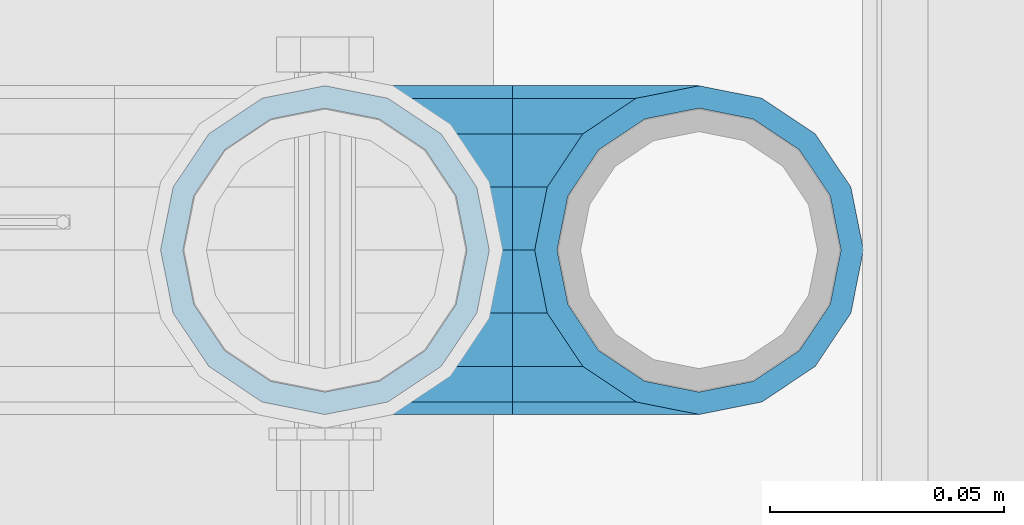
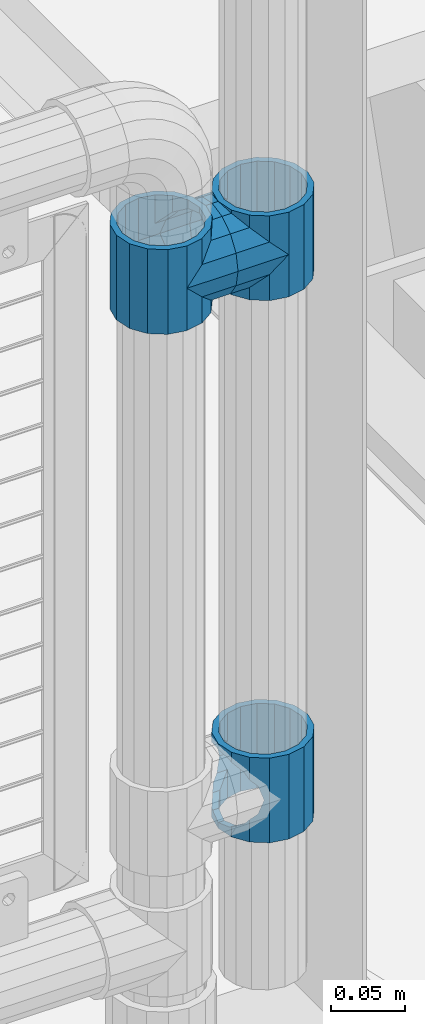
# One storey, part 140 of 208: 5 beams.
"""IFC2X3 building model written with IfcOpenShell, lengths in millimetres."""

from ifc_helpers import new_model, si_unit, frame, origin_with_axes, place, context, subcontext, project, spatial, faceted_brep, material, type_object, element, save


model = new_model("IFC2X3")

# Units and contexts
model_context = context("Model", 3, precision=1e-05, world=origin_with_axes())
body_context = subcontext(model_context, "Body", "Model", "MODEL_VIEW")
ifc_project = project(units=[si_unit("LENGTHUNIT", "METRE", prefix="MILLI"), si_unit("AREAUNIT", "SQUARE_METRE"), si_unit("VOLUMEUNIT", "CUBIC_METRE"), si_unit("MASSUNIT", "GRAM", prefix="KILO"), si_unit("TIMEUNIT", "SECOND"), si_unit("PLANEANGLEUNIT", "RADIAN"), si_unit("SOLIDANGLEUNIT", "STERADIAN"), si_unit("THERMODYNAMICTEMPERATUREUNIT", "DEGREE_CELSIUS"), si_unit("LUMINOUSINTENSITYUNIT", "LUMEN")], contexts=[model_context])

# Site, building, storey
site_placement = place(None, origin_with_axes())
site = spatial("IfcSite", under=ifc_project, at=site_placement, CompositionType="ELEMENT")
building_placement = place(site_placement, origin_with_axes())
building = spatial("IfcBuilding", under=site, at=building_placement, Name="Standard", CompositionType="ELEMENT")
storey_placement = place(building_placement, origin_with_axes())
storey = spatial("IfcBuildingStorey", under=building, at=storey_placement, Name="Undefined", CompositionType="ELEMENT", Elevation=0.0)

# Beams
ifc_material = material(Name="Misc_Undefined")
beam_type = type_object("IfcBeamType", PredefinedType="NOTDEFINED")
beam_1_placement = place(storey_placement, frame((-26149.0, 4664.5, 433.82), z_axis=(1.0, 0.0, 0.0), x_axis=(0.0, 0.0, -1.0)))
element("IfcBeam", 1, at=beam_1_placement, inside=storey, type_object=beam_type, material=ifc_material, context=body_context, shape_type="Brep", body=[
    faceted_brep([(56.6106908090114, 21.4606908090118, -27.1226768591077), (56.6106908090114, 21.4606908090118, -21.4606908090136), (46.7644421722801, 28.0397438117179, -11.6144421722784), (46.7644421722801, 28.0397438117179, -20.0882031229921), (51.531042408003, 24.8548033587067, -24.8548033587067), (63.1897438117172, 11.6144421722802, -32.8397438117245), (63.1897438117172, 11.6144421722802, -28.0397438117143), (61.962379517676, 13.4513226476329, -32.4743655677739), (65.4999999999997, 0.0, -35.1500000000015), (65.4999999999997, 0.0, -30.3499999999985), (63.1897438117172, -11.6144421722802, -32.8397438117245), (63.1897438117172, -11.6144421722802, -28.0397438117143), (61.962379517675, -13.4513226476329, -32.4743655677739), (56.6106908090114, -21.4606908090118, -27.1226768591005), (56.6106908090114, -21.4606908090118, -21.4606908090136), (51.531042408003, -24.8548033587067, -24.8548033587067), (46.7644421722801, -28.0397438117179, -20.0882031229921), (46.7644421722801, -28.0397438117179, -11.6144421722784), (35.1499999999996, -30.3500000000004, -16.6306603983685), (35.1500000000015, -30.35, 0.0), (23.5355578277191, -28.0397438117179, -20.0882031229921), (23.5355578277191, -28.0397438117179, -11.6144421722784), (13.6893091909879, -21.4606908090118, -27.1226768591005), (13.6893091909879, -21.4606908090118, -21.4606908090136), (18.7689575919962, -24.8548033587067, -24.8548033587067), (7.11025618828205, -11.6144421722802, -32.8397438117245), (7.11025618828205, -11.6144421722802, -28.0397438117143), (8.33762048232325, -13.4513226476329, -32.4743655677739), (4.79999999999961, 0.0, -35.1500000000015), (4.79999999999961, 0.0, -30.3499999999985), (7.11025618828211, 11.6144421722802, -32.8397438117245), (7.11025618828211, 11.6144421722802, -28.0397438117143), (8.33762048232325, 13.4513226476329, -32.4743655677739), (13.6893091909879, 21.4606908090118, -27.1226768591077), (13.6893091909879, 21.4606908090118, -21.4606908090136), (18.7689575919962, 24.8548033587067, -24.8548033587067), (23.5355578277192, 28.0397438117179, -20.0882031229921), (23.5355578277192, 28.0397438117179, -11.6144421722784), (35.1499999999996, 30.3500000000004, -16.6306603983685), (35.1500000000015, 30.35, 0.0), (0.0, 32.4743655677721, -13.4513226476338), (0.0, 35.1499999999996, 0.0), (70.2999999999993, 35.1499999999996, 0.0), (70.2999999999993, 32.4743655677721, -13.4513226476338), (0.0, 32.4743655677721, 13.4513226476338), (70.2999999999993, 32.4743655677721, 13.4513226476338), (0.0, 24.8548033587067, 24.8548033587067), (70.2999999999993, 24.8548033587067, 24.8548033587067), (0.0, 13.4513226476329, 32.4743655677739), (70.2999999999993, 13.4513226476329, 32.4743655677739), (0.0, 0.0, 35.1499999999996), (70.2999999999993, 0.0, 35.1500000000015), (0.0, -13.4513226476329, 32.4743655677739), (70.2999999999993, -13.4513226476329, 32.4743655677739), (0.0, -24.8548033587067, 24.8548033587067), (70.2999999999993, -24.8548033587067, 24.8548033587067), (0.0, -32.4743655677721, 13.4513226476338), (70.2999999999993, -32.4743655677721, 13.4513226476338), (0.0, -35.1499999999996, 0.0), (70.2999999999993, -35.1499999999996, 0.0), (70.2999999999993, -30.3500000000004, 0.0), (70.2999999999993, -28.0397438117179, -11.6144421722784), (70.2999999999993, -21.4606908090118, -21.4606908090136), (70.2999999999993, -11.6144421722802, -28.0397438117143), (70.2999999999993, 0.0, -30.3499999999985), (70.2999999999993, 11.6144421722802, -28.0397438117143), (70.2999999999993, 21.4606908090118, -21.4606908090136), (70.2999999999993, 28.0397438117179, -11.6144421722784), (0.0, -28.0397438117179, -11.6144421722784), (0.0, -30.3500000000004, 0.0), (0.0, -21.4606908090118, -21.4606908090136), (0.0, -11.6144421722802, -28.0397438117143), (0.0, 0.0, -30.3499999999985), (0.0, 11.6144421722802, -28.0397438117143), (0.0, 21.4606908090118, -21.4606908090136), (0.0, 28.0397438117179, -11.6144421722784), (0.0, 30.3500000000004, 0.0), (70.2999999999993, 30.3500000000004, 0.0), (0.0, 28.0397438117179, 11.6144421722784), (70.2999999999993, 28.0397438117179, 11.6144421722784), (0.0, 21.4606908090118, 21.4606908090136), (70.2999999999993, 21.4606908090118, 21.4606908090136), (0.0, 11.6144421722802, 28.0397438117143), (70.2999999999993, 11.6144421722802, 28.0397438117143), (0.0, 0.0, 30.3499999999985), (70.2999999999993, 0.0, 30.3499999999985), (0.0, -11.6144421722802, 28.0397438117143), (70.2999999999993, -11.6144421722802, 28.0397438117143), (0.0, -21.4606908090118, 21.4606908090136), (70.2999999999993, -21.4606908090118, 21.4606908090136), (0.0, -28.0397438117179, 11.6144421722784), (70.2999999999993, -28.0397438117179, 11.6144421722784), (70.2999999999993, -24.8548033587067, -24.8548033587067), (70.2999999999993, -13.4513226476329, -32.4743655677739), (70.2999999999993, 0.0, -35.1500000000015), (70.2999999999993, 13.4513226476329, -32.4743655677739), (70.2999999999993, 24.8548033587067, -24.8548033587067), (70.2999999999993, -32.4743655677721, -13.4513226476338), (0.0, -32.4743655677721, -13.4513226476338), (0.0, 24.8548033587067, -24.8548033587067), (0.0, 13.4513226476329, -32.4743655677739), (0.0, 0.0, -35.1499999999996), (0.0, -13.4513226476329, -32.4743655677739), (0.0, -24.8548033587067, -24.8548033587067)], [[[0, 1, 2, 3, 4]], [[5, 6, 1, 0, 7]], [[8, 9, 6, 5]], [[10, 11, 9, 8]], [[12, 13, 14, 11, 10]], [[15, 16, 17, 14, 13]], [[18, 19, 17, 16]], [[20, 21, 19, 18]], [[22, 23, 21, 20, 24]], [[25, 26, 23, 22, 27]], [[28, 29, 26, 25]], [[30, 31, 29, 28]], [[32, 33, 34, 31, 30]], [[35, 36, 37, 34, 33]], [[38, 39, 37, 36]], [[3, 2, 39, 38]], [[40, 41, 42, 43]], [[41, 44, 45, 42]], [[44, 46, 47, 45]], [[46, 48, 49, 47]], [[48, 50, 51, 49]], [[50, 52, 53, 51]], [[52, 54, 55, 53]], [[54, 56, 57, 55]], [[56, 58, 59, 57]], [[60, 61, 17, 19]], [[61, 62, 14, 17]], [[62, 63, 11, 14]], [[63, 64, 9, 11]], [[64, 65, 6, 9]], [[65, 66, 1, 6]], [[66, 67, 2, 1]], [[68, 69, 19, 21]], [[70, 68, 21, 23]], [[71, 70, 23, 26]], [[72, 71, 26, 29]], [[73, 72, 29, 31]], [[74, 73, 31, 34]], [[75, 74, 34, 37]], [[76, 75, 37, 39]], [[67, 77, 39, 2]], [[78, 76, 39, 77, 79]], [[80, 78, 79, 81]], [[82, 80, 81, 83]], [[84, 82, 83, 85]], [[86, 84, 85, 87]], [[88, 86, 87, 89]], [[90, 88, 89, 91]], [[19, 69, 90, 91, 60]], [[92, 93, 94, 95, 96, 43, 42, 45, 47, 49, 51, 53, 55, 57, 59, 97], [89, 87, 85, 83, 81, 79, 77, 67, 66, 65, 64, 63, 62, 61, 60, 91]], [[58, 98, 97, 59]], [[56, 54, 52, 50, 48, 46, 44, 41, 40, 99, 100, 101, 102, 103, 98, 58], [68, 70, 71, 72, 73, 74, 75, 76, 78, 80, 82, 84, 86, 88, 90, 69]], [[100, 99, 35, 33, 32]], [[101, 100, 32, 30, 28]], [[27, 102, 101, 28, 25]], [[24, 103, 102, 27, 22]], [[92, 97, 98, 103, 24, 20, 18, 16, 15]], [[93, 92, 15, 13, 12]], [[94, 93, 12, 10, 8]], [[7, 95, 94, 8, 5]], [[4, 96, 95, 7, 0]], [[38, 36, 35, 99, 40, 43, 96, 4, 3]]]),
])
beam_2_placement = place(storey_placement, frame((-26229.0, 4664.5, 848.670000000001), z_axis=(0.0, -1.0, 0.0), x_axis=(1.0, 0.0, 0.0)))
element("IfcBeam", 2, at=beam_2_placement, inside=storey, type_object=beam_type, material=ifc_material, context=body_context, shape_type="Brep", body=[
    faceted_brep([(13.4513226476338, -13.4513226476329, -32.4743655677721), (13.4513226476338, 13.4513226476329, -32.4743655677721), (0.0, 0.0, -35.1499999999996), (27.1226768591005, 21.4606908090117, 21.4606908090118), (24.8548033587067, 16.3810424080032, 24.8548033587067), (24.8548033587067, 24.8548033587072, 24.8548033587067), (32.4743655677739, 32.4743655677717, 13.4513226476329), (32.4743655677739, 26.812379517676, 13.4513226476329), (0.0, 0.0, 35.1499999999996), (13.4513226476338, 13.4513226476329, 32.4743655677721), (13.4513226476338, -13.4513226476329, 32.4743655677721), (20.0882031229921, 11.6144421722805, 28.0397438117179), (16.6306603983685, 0.0, 30.3500000000004), (20.0882031229921, -11.6144421722805, 28.0397438117179), (24.8548033587067, -16.3810424080039, 24.8548033587067), (24.8548033587067, -24.8548033587072, 24.8548033587067), (27.1226768591005, -21.4606908090117, 21.4606908090118), (32.4743655677739, -26.8123795176755, 13.4513226476329), (32.4743655677739, -32.4743655677717, 13.4513226476329), (32.8397438117172, -28.0397438117175, 11.6144421722802), (35.1500000000015, -30.35, 0.0), (35.1500000000015, -35.1499999999996, 0.0), (32.8397438117172, -28.0397438117175, -11.6144421722802), (32.4743655677739, -26.8123795176766, -13.4513226476329), (32.4743655677739, -32.4743655677717, -13.4513226476329), (27.1226768591077, -21.4606908090117, -21.4606908090118), (24.8548033587067, -16.3810424080039, -24.8548033587067), (24.8548033587067, -24.8548033587072, -24.8548033587067), (20.0882031229849, -11.6144421722805, -28.0397438117179), (16.6306603983685, 0.0, -30.3500000000004), (20.0882031229849, 11.6144421722805, -28.0397438117179), (24.8548033587067, 16.3810424080023, -24.8548033587067), (24.8548033587067, 24.8548033587072, -24.8548033587067), (32.4743655677739, 26.8123795176755, -13.4513226476329), (32.4743655677739, 32.4743655677717, -13.4513226476329), (27.1226768591077, 21.4606908090117, -21.4606908090118), (35.1500000000015, 30.35, 0.0), (35.1500000000015, 35.15, 0.0), (32.8397438117172, 28.0397438117175, -11.6144421722802), (32.8397438117172, 28.0397438117175, 11.6144421722802), (40.1500000000015, -35.15, 0.0), (40.1500000000015, -32.4743655677717, 13.4513226476329), (40.1500000000015, -24.8548033587072, 24.8548033587067), (40.1500000000015, -13.4513226476329, 32.4743655677721), (40.1500000000015, 0.0, 35.1499999999996), (40.1500000000015, 13.4513226476329, 32.4743655677721), (40.1500000000015, 24.8548033587072, 24.8548033587067), (40.1500000000015, 32.4743655677717, 13.4513226476329), (40.1500000000015, 35.15, 0.0), (40.1500000000015, -24.8548033587072, -24.8548033587067), (40.1500000000015, -32.4743655677717, -13.4513226476329), (40.1500000000015, -13.4513226476329, -32.4743655677721), (40.1500000000015, 0.0, -35.1499999999996), (40.1500000000015, 13.4513226476329, -32.4743655677721), (40.1500000000015, 24.8548033587072, -24.8548033587067), (40.1500000000015, 32.4743655677717, -13.4513226476329), (40.1500000000015, -21.4606908090117, 21.4606908090118), (40.1500000000015, -11.6144421722805, 28.0397438117179), (40.1500000000015, 0.0, 30.3500000000004), (40.1500000000015, 11.6144421722805, 28.0397438117179), (40.1500000000015, 21.4606908090117, 21.4606908090118), (40.1500000000015, 28.0397438117175, 11.6144421722802), (40.1500000000015, 30.35, 0.0), (40.1500000000015, 28.0397438117175, -11.6144421722802), (40.1500000000015, 21.4606908090117, -21.4606908090118), (40.1500000000015, 11.6144421722805, -28.0397438117179), (40.1500000000015, 0.0, -30.3500000000004), (40.1500000000015, -11.6144421722805, -28.0397438117179), (40.1500000000015, -21.4606908090117, -21.4606908090118), (40.1500000000015, -28.0397438117175, -11.6144421722802), (40.1500000000015, -30.35, 0.0), (40.1500000000015, -28.0397438117175, 11.6144421722802)], [[[0, 1, 2]], [[3, 4, 5, 6, 7]], [[8, 9, 10]], [[10, 9, 5, 4, 11, 12, 13, 14, 15]], [[15, 14, 16, 17, 18]], [[18, 17, 19, 20, 21]], [[21, 20, 22, 23, 24]], [[24, 23, 25, 26, 27]], [[27, 26, 28, 29, 30, 31, 32, 1, 0]], [[33, 34, 32, 31, 35]], [[36, 37, 34, 33, 38]], [[39, 7, 6, 37, 36]], [[40, 41, 18, 21]], [[41, 42, 15, 18]], [[42, 43, 10, 15]], [[43, 44, 8, 10]], [[44, 45, 9, 8]], [[45, 46, 5, 9]], [[46, 47, 6, 5]], [[47, 48, 37, 6]], [[49, 50, 24, 27]], [[51, 49, 27, 0]], [[52, 51, 0, 2]], [[53, 52, 2, 1]], [[54, 53, 1, 32]], [[55, 54, 32, 34]], [[48, 55, 34, 37]], [[50, 40, 21, 24]], [[49, 51, 52, 53, 54, 55, 48, 47, 46, 45, 44, 43, 42, 41, 40, 50], [56, 57, 58, 59, 60, 61, 62, 63, 64, 65, 66, 67, 68, 69, 70, 71]], [[63, 62, 36, 38]], [[35, 64, 63, 38, 33]], [[30, 65, 64, 35, 31]], [[66, 65, 30, 29]], [[67, 66, 29, 28]], [[68, 67, 28, 26, 25]], [[69, 68, 25, 23, 22]], [[70, 69, 22, 20]], [[71, 70, 20, 19]], [[16, 56, 71, 19, 17]], [[13, 57, 56, 16, 14]], [[58, 57, 13, 12]], [[59, 58, 12, 11]], [[60, 59, 11, 4, 3]], [[61, 60, 3, 7, 39]], [[62, 61, 39, 36]]]),
])
beam_3_placement = place(storey_placement, frame((-26149.0, 4664.5, 848.670000000001), z_axis=(0.0, 1.0, 0.0), x_axis=(-1.0, 0.0, 0.0)))
element("IfcBeam", 3, at=beam_3_placement, inside=storey, type_object=beam_type, material=ifc_material, context=body_context, shape_type="Brep", body=[
    faceted_brep([(13.4513226476338, -13.4513226476329, -32.4743655677721), (13.4513226476338, 13.4513226476329, -32.4743655677721), (0.0, 0.0, -35.1499999999996), (24.8548033587067, -24.8548033587072, 24.8548033587067), (24.8548033587067, -16.3810424080039, 24.8548033587067), (27.1226768591005, -21.4606908090117, 21.4606908090118), (32.4743655677739, -26.8123795176755, 13.4513226476329), (32.4743655677739, -32.4743655677717, 13.4513226476329), (32.8397438117172, -28.0397438117175, 11.6144421722802), (35.1500000000015, -30.35, 0.0), (35.1500000000015, -35.1499999999996, 0.0), (32.8397438117172, -28.0397438117175, -11.6144421722802), (32.4743655677739, -26.8123795176766, -13.4513226476329), (32.4743655677739, -32.4743655677717, -13.4513226476329), (27.1226768591077, -21.4606908090117, -21.4606908090118), (24.8548033587067, -16.3810424080039, -24.8548033587067), (24.8548033587067, -24.8548033587072, -24.8548033587067), (20.0882031229849, -11.6144421722805, -28.0397438117179), (16.6306603983685, 0.0, -30.3500000000004), (20.0882031229849, 11.6144421722805, -28.0397438117179), (24.8548033587067, 16.3810424080023, -24.8548033587067), (24.8548033587067, 24.8548033587072, -24.8548033587067), (32.4743655677739, 26.8123795176755, -13.4513226476329), (32.4743655677739, 32.4743655677717, -13.4513226476329), (27.1226768591077, 21.4606908090117, -21.4606908090118), (35.1500000000015, 30.35, 0.0), (35.1500000000015, 35.15, 0.0), (32.8397438117172, 28.0397438117175, -11.6144421722802), (32.8397438117172, 28.0397438117175, 11.6144421722802), (32.4743655677739, 26.812379517676, 13.4513226476329), (32.4743655677739, 32.4743655677717, 13.4513226476329), (27.1226768591005, 21.4606908090117, 21.4606908090118), (24.8548033587067, 16.3810424080032, 24.8548033587067), (24.8548033587067, 24.8548033587072, 24.8548033587067), (0.0, 0.0, 35.1499999999996), (13.4513226476338, 13.4513226476329, 32.4743655677721), (13.4513226476338, -13.4513226476329, 32.4743655677721), (20.0882031229921, 11.6144421722805, 28.0397438117179), (16.6306603983685, 0.0, 30.3500000000004), (20.0882031229921, -11.6144421722805, 28.0397438117179), (40.1500000000015, -35.15, 0.0), (40.1500000000015, -32.4743655677717, 13.4513226476329), (40.1500000000015, -24.8548033587072, 24.8548033587067), (40.1500000000015, -13.4513226476329, 32.4743655677721), (40.1500000000015, 0.0, 35.1499999999996), (40.1500000000015, -24.8548033587072, -24.8548033587067), (40.1500000000015, -32.4743655677717, -13.4513226476329), (40.1500000000015, -13.4513226476329, -32.4743655677721), (40.1500000000015, 0.0, -35.1499999999996), (40.1500000000015, 13.4513226476329, -32.4743655677721), (40.1500000000015, 24.8548033587072, -24.8548033587067), (40.1500000000015, 32.4743655677717, -13.4513226476329), (40.1500000000015, 35.15, 0.0), (40.1500000000015, 32.4743655677717, 13.4513226476329), (40.1500000000015, 24.8548033587072, 24.8548033587067), (40.1500000000015, 13.4513226476329, 32.4743655677721), (40.1500000000015, -21.4606908090117, 21.4606908090118), (40.1500000000015, -11.6144421722805, 28.0397438117179), (40.1500000000015, 0.0, 30.3500000000004), (40.1500000000015, 11.6144421722805, 28.0397438117179), (40.1500000000015, 21.4606908090117, 21.4606908090118), (40.1500000000015, 28.0397438117175, 11.6144421722802), (40.1500000000015, 30.35, 0.0), (40.1500000000015, 28.0397438117175, -11.6144421722802), (40.1500000000015, 21.4606908090117, -21.4606908090118), (40.1500000000015, 11.6144421722805, -28.0397438117179), (40.1500000000015, 0.0, -30.3500000000004), (40.1500000000015, -11.6144421722805, -28.0397438117179), (40.1500000000015, -21.4606908090117, -21.4606908090118), (40.1500000000015, -28.0397438117175, -11.6144421722802), (40.1500000000015, -30.35, 0.0), (40.1500000000015, -28.0397438117175, 11.6144421722802)], [[[0, 1, 2]], [[3, 4, 5, 6, 7]], [[7, 6, 8, 9, 10]], [[10, 9, 11, 12, 13]], [[13, 12, 14, 15, 16]], [[16, 15, 17, 18, 19, 20, 21, 1, 0]], [[22, 23, 21, 20, 24]], [[25, 26, 23, 22, 27]], [[28, 29, 30, 26, 25]], [[31, 32, 33, 30, 29]], [[34, 35, 36]], [[36, 35, 33, 32, 37, 38, 39, 4, 3]], [[40, 41, 7, 10]], [[41, 42, 3, 7]], [[42, 43, 36, 3]], [[43, 44, 34, 36]], [[45, 46, 13, 16]], [[47, 45, 16, 0]], [[48, 47, 0, 2]], [[49, 48, 2, 1]], [[50, 49, 1, 21]], [[51, 50, 21, 23]], [[52, 51, 23, 26]], [[53, 52, 26, 30]], [[54, 53, 30, 33]], [[55, 54, 33, 35]], [[44, 55, 35, 34]], [[46, 40, 10, 13]], [[45, 47, 48, 49, 50, 51, 52, 53, 54, 55, 44, 43, 42, 41, 40, 46], [56, 57, 58, 59, 60, 61, 62, 63, 64, 65, 66, 67, 68, 69, 70, 71]], [[59, 58, 38, 37]], [[60, 59, 37, 32, 31]], [[61, 60, 31, 29, 28]], [[62, 61, 28, 25]], [[63, 62, 25, 27]], [[24, 64, 63, 27, 22]], [[19, 65, 64, 24, 20]], [[66, 65, 19, 18]], [[67, 66, 18, 17]], [[68, 67, 17, 15, 14]], [[69, 68, 14, 12, 11]], [[70, 69, 11, 9]], [[71, 70, 9, 8]], [[5, 56, 71, 8, 6]], [[39, 57, 56, 5, 4]], [[58, 57, 39, 38]]]),
])
beam_4_placement = place(storey_placement, frame((-26229.0, 4664.5, 883.82), z_axis=(-1.0, 0.0, 0.0), x_axis=(0.0, 0.0, -1.0)))
element("IfcBeam", 4, at=beam_4_placement, inside=storey, type_object=beam_type, material=ifc_material, context=body_context, shape_type="Brep", body=[
    faceted_brep([(7.11025618828205, -11.6144421722802, -32.8397438117245), (7.11025618828205, -11.6144421722802, -28.0397438117143), (13.6893091909879, -21.4606908090118, -21.4606908090136), (13.6893091909879, -21.4606908090118, -27.1226768591005), (8.33762048232325, -13.4513226476329, -32.4743655677739), (23.5355578277191, -28.0397438117179, -11.6144421722784), (23.5355578277191, -28.0397438117179, -20.0882031229921), (18.7689575919962, -24.8548033587067, -24.8548033587067), (35.1500000000015, -30.35, 0.0), (35.1499999999996, -30.3500000000004, -16.6306603983685), (46.7644421722801, -28.0397438117179, -11.6144421722784), (46.7644421722801, -28.0397438117179, -20.0882031229921), (51.531042408003, -24.8548033587067, -24.8548033587067), (56.6106908090114, -21.4606908090118, -21.4606908090136), (56.6106908090114, -21.4606908090118, -27.1226768591005), (61.962379517675, -13.4513226476329, -32.4743655677739), (63.1897438117172, -11.6144421722802, -28.0397438117143), (63.1897438117172, -11.6144421722802, -32.8397438117245), (65.4999999999997, 0.0, -30.3499999999985), (65.4999999999997, 0.0, -35.1500000000015), (63.1897438117172, 11.6144421722802, -28.0397438117143), (63.1897438117172, 11.6144421722802, -32.8397438117245), (56.6106908090114, 21.4606908090118, -21.4606908090136), (56.6106908090114, 21.4606908090118, -27.1226768591077), (61.962379517676, 13.4513226476329, -32.4743655677739), (46.7644421722801, 28.0397438117179, -11.6144421722784), (46.7644421722801, 28.0397438117179, -20.0882031229921), (51.531042408003, 24.8548033587067, -24.8548033587067), (35.1500000000015, 30.35, 0.0), (35.1499999999996, 30.3500000000004, -16.6306603983685), (23.5355578277192, 28.0397438117179, -11.6144421722784), (23.5355578277192, 28.0397438117179, -20.0882031229921), (18.7689575919962, 24.8548033587067, -24.8548033587067), (13.6893091909879, 21.4606908090118, -21.4606908090136), (13.6893091909879, 21.4606908090118, -27.1226768591077), (8.33762048232325, 13.4513226476329, -32.4743655677739), (7.11025618828211, 11.6144421722802, -28.0397438117143), (7.11025618828211, 11.6144421722802, -32.8397438117245), (4.79999999999961, 0.0, -30.3499999999985), (4.79999999999961, 0.0, -35.1500000000015), (0.0, 21.4606908090118, 21.4606908090136), (0.0, 28.0397438117179, 11.6144421722784), (70.2999999999993, 28.0397438117179, 11.6144421722784), (70.2999999999993, 21.4606908090118, 21.4606908090136), (0.0, 11.6144421722802, 28.0397438117143), (70.2999999999993, 11.6144421722802, 28.0397438117143), (0.0, 0.0, 30.3499999999985), (70.2999999999993, 0.0, 30.3499999999985), (0.0, -11.6144421722802, 28.0397438117143), (70.2999999999993, -11.6144421722802, 28.0397438117143), (0.0, -21.4606908090118, 21.4606908090136), (70.2999999999993, -21.4606908090118, 21.4606908090136), (0.0, -28.0397438117179, 11.6144421722784), (70.2999999999993, -28.0397438117179, 11.6144421722784), (0.0, -24.8548033587067, -24.8548033587067), (0.0, -13.4513226476329, -32.4743655677739), (0.0, 0.0, -35.1499999999996), (0.0, -32.4743655677721, 13.4513226476338), (0.0, -35.1499999999996, 0.0), (70.2999999999993, -35.1499999999996, 0.0), (70.2999999999993, -32.4743655677721, 13.4513226476338), (0.0, -24.8548033587067, 24.8548033587067), (70.2999999999993, -24.8548033587067, 24.8548033587067), (0.0, -13.4513226476329, 32.4743655677739), (70.2999999999993, -13.4513226476329, 32.4743655677739), (0.0, 0.0, 35.1499999999996), (70.2999999999993, 0.0, 35.1500000000015), (0.0, 13.4513226476329, 32.4743655677739), (70.2999999999993, 13.4513226476329, 32.4743655677739), (0.0, 24.8548033587067, 24.8548033587067), (70.2999999999993, 24.8548033587067, 24.8548033587067), (0.0, 32.4743655677721, 13.4513226476338), (70.2999999999993, 32.4743655677721, 13.4513226476338), (0.0, 35.1499999999996, 0.0), (70.2999999999993, 35.1499999999996, 0.0), (0.0, 32.4743655677721, -13.4513226476338), (70.2999999999993, 32.4743655677721, -13.4513226476338), (70.2999999999993, -13.4513226476329, -32.4743655677739), (70.2999999999993, -24.8548033587067, -24.8548033587067), (70.2999999999993, 0.0, -35.1500000000015), (70.2999999999993, 13.4513226476329, -32.4743655677739), (70.2999999999993, 24.8548033587067, -24.8548033587067), (0.0, 24.8548033587067, -24.8548033587067), (0.0, 13.4513226476329, -32.4743655677739), (70.2999999999993, -32.4743655677721, -13.4513226476338), (0.0, -32.4743655677721, -13.4513226476338), (0.0, -28.0397438117179, -11.6144421722784), (0.0, -21.4606908090118, -21.4606908090136), (0.0, -11.6144421722802, -28.0397438117143), (0.0, 0.0, -30.3499999999985), (0.0, 11.6144421722802, -28.0397438117143), (0.0, 21.4606908090118, -21.4606908090136), (0.0, 28.0397438117179, -11.6144421722784), (0.0, 30.3500000000004, 0.0), (0.0, -30.3500000000004, 0.0), (70.2999999999993, 30.3500000000004, 0.0), (70.2999999999993, 28.0397438117179, -11.6144421722784), (70.2999999999993, 21.4606908090118, -21.4606908090136), (70.2999999999993, 11.6144421722802, -28.0397438117143), (70.2999999999993, 0.0, -30.3499999999985), (70.2999999999993, -11.6144421722802, -28.0397438117143), (70.2999999999993, -21.4606908090118, -21.4606908090136), (70.2999999999993, -28.0397438117179, -11.6144421722784), (70.2999999999993, -30.3500000000004, 0.0)], [[[0, 1, 2, 3, 4]], [[3, 2, 5, 6, 7]], [[6, 5, 8, 9]], [[9, 8, 10, 11]], [[12, 11, 10, 13, 14]], [[15, 14, 13, 16, 17]], [[17, 16, 18, 19]], [[19, 18, 20, 21]], [[21, 20, 22, 23, 24]], [[23, 22, 25, 26, 27]], [[26, 25, 28, 29]], [[29, 28, 30, 31]], [[32, 31, 30, 33, 34]], [[35, 34, 33, 36, 37]], [[37, 36, 38, 39]], [[39, 38, 1, 0]], [[40, 41, 42, 43]], [[44, 40, 43, 45]], [[46, 44, 45, 47]], [[48, 46, 47, 49]], [[50, 48, 49, 51]], [[52, 50, 51, 53]], [[7, 54, 55, 4, 3]], [[4, 55, 56, 39, 0]], [[57, 58, 59, 60]], [[61, 57, 60, 62]], [[63, 61, 62, 64]], [[65, 63, 64, 66]], [[67, 65, 66, 68]], [[69, 67, 68, 70]], [[71, 69, 70, 72]], [[73, 71, 72, 74]], [[75, 73, 74, 76]], [[77, 78, 12, 14, 15]], [[79, 77, 15, 17, 19]], [[24, 80, 79, 19, 21]], [[27, 81, 80, 24, 23]], [[29, 31, 32, 82, 75, 76, 81, 27, 26]], [[83, 82, 32, 34, 35]], [[56, 83, 35, 37, 39]], [[78, 84, 85, 54, 7, 6, 9, 11, 12]], [[58, 85, 84, 59]], [[57, 61, 63, 65, 67, 69, 71, 73, 75, 82, 83, 56, 55, 54, 85, 58], [86, 87, 88, 89, 90, 91, 92, 93, 41, 40, 44, 46, 48, 50, 52, 94]], [[90, 89, 38, 36]], [[91, 90, 36, 33]], [[92, 91, 33, 30]], [[93, 92, 30, 28]], [[41, 93, 28, 95, 42]], [[96, 95, 28, 25]], [[97, 96, 25, 22]], [[98, 97, 22, 20]], [[99, 98, 20, 18]], [[100, 99, 18, 16]], [[101, 100, 16, 13]], [[102, 101, 13, 10]], [[103, 102, 10, 8]], [[78, 77, 79, 80, 81, 76, 74, 72, 70, 68, 66, 64, 62, 60, 59, 84], [51, 49, 47, 45, 43, 42, 95, 96, 97, 98, 99, 100, 101, 102, 103, 53]], [[8, 94, 52, 53, 103]], [[86, 94, 8, 5]], [[87, 86, 5, 2]], [[88, 87, 2, 1]], [[89, 88, 1, 38]]]),
])
beam_5_placement = place(storey_placement, frame((-26149.0, 4664.5, 883.82), z_axis=(1.0, 0.0, 0.0), x_axis=(0.0, 0.0, -1.0)))
element("IfcBeam", 5, at=beam_5_placement, inside=storey, type_object=beam_type, material=ifc_material, context=body_context, shape_type="Brep", body=[
    faceted_brep([(56.6106908090114, 21.4606908090118, -27.1226768591077), (56.6106908090114, 21.4606908090118, -21.4606908090136), (46.7644421722801, 28.0397438117179, -11.6144421722784), (46.7644421722801, 28.0397438117179, -20.0882031229921), (51.531042408003, 24.8548033587067, -24.8548033587067), (63.1897438117172, 11.6144421722802, -32.8397438117245), (63.1897438117172, 11.6144421722802, -28.0397438117143), (61.962379517676, 13.4513226476329, -32.4743655677739), (65.4999999999997, 0.0, -35.1500000000015), (65.4999999999997, 0.0, -30.3499999999985), (63.1897438117172, -11.6144421722802, -32.8397438117245), (63.1897438117172, -11.6144421722802, -28.0397438117143), (61.962379517675, -13.4513226476329, -32.4743655677739), (56.6106908090114, -21.4606908090118, -27.1226768591005), (56.6106908090114, -21.4606908090118, -21.4606908090136), (51.531042408003, -24.8548033587067, -24.8548033587067), (46.7644421722801, -28.0397438117179, -20.0882031229921), (46.7644421722801, -28.0397438117179, -11.6144421722784), (35.1499999999996, -30.3500000000004, -16.6306603983685), (35.1500000000015, -30.35, 0.0), (23.5355578277191, -28.0397438117179, -20.0882031229921), (23.5355578277191, -28.0397438117179, -11.6144421722784), (13.6893091909879, -21.4606908090118, -27.1226768591005), (13.6893091909879, -21.4606908090118, -21.4606908090136), (18.7689575919962, -24.8548033587067, -24.8548033587067), (7.11025618828205, -11.6144421722802, -32.8397438117245), (7.11025618828205, -11.6144421722802, -28.0397438117143), (8.33762048232325, -13.4513226476329, -32.4743655677739), (4.79999999999961, 0.0, -35.1500000000015), (4.79999999999961, 0.0, -30.3499999999985), (7.11025618828211, 11.6144421722802, -32.8397438117245), (7.11025618828211, 11.6144421722802, -28.0397438117143), (8.33762048232325, 13.4513226476329, -32.4743655677739), (13.6893091909879, 21.4606908090118, -27.1226768591077), (13.6893091909879, 21.4606908090118, -21.4606908090136), (18.7689575919962, 24.8548033587067, -24.8548033587067), (23.5355578277192, 28.0397438117179, -20.0882031229921), (23.5355578277192, 28.0397438117179, -11.6144421722784), (35.1499999999996, 30.3500000000004, -16.6306603983685), (35.1500000000015, 30.35, 0.0), (0.0, 32.4743655677721, -13.4513226476338), (0.0, 35.1499999999996, 0.0), (70.2999999999993, 35.1499999999996, 0.0), (70.2999999999993, 32.4743655677721, -13.4513226476338), (0.0, 32.4743655677721, 13.4513226476338), (70.2999999999993, 32.4743655677721, 13.4513226476338), (0.0, 24.8548033587067, 24.8548033587067), (70.2999999999993, 24.8548033587067, 24.8548033587067), (0.0, 13.4513226476329, 32.4743655677739), (70.2999999999993, 13.4513226476329, 32.4743655677739), (0.0, 0.0, 35.1499999999996), (70.2999999999993, 0.0, 35.1500000000015), (0.0, -13.4513226476329, 32.4743655677739), (70.2999999999993, -13.4513226476329, 32.4743655677739), (0.0, -24.8548033587067, 24.8548033587067), (70.2999999999993, -24.8548033587067, 24.8548033587067), (0.0, -32.4743655677721, 13.4513226476338), (70.2999999999993, -32.4743655677721, 13.4513226476338), (0.0, -35.1499999999996, 0.0), (70.2999999999993, -35.1499999999996, 0.0), (70.2999999999993, -30.3500000000004, 0.0), (70.2999999999993, -28.0397438117179, -11.6144421722784), (70.2999999999993, -21.4606908090118, -21.4606908090136), (70.2999999999993, -11.6144421722802, -28.0397438117143), (70.2999999999993, 0.0, -30.3499999999985), (70.2999999999993, 11.6144421722802, -28.0397438117143), (70.2999999999993, 21.4606908090118, -21.4606908090136), (70.2999999999993, 28.0397438117179, -11.6144421722784), (0.0, -28.0397438117179, -11.6144421722784), (0.0, -30.3500000000004, 0.0), (0.0, -21.4606908090118, -21.4606908090136), (0.0, -11.6144421722802, -28.0397438117143), (0.0, 0.0, -30.3499999999985), (0.0, 11.6144421722802, -28.0397438117143), (0.0, 21.4606908090118, -21.4606908090136), (0.0, 28.0397438117179, -11.6144421722784), (0.0, 30.3500000000004, 0.0), (70.2999999999993, 30.3500000000004, 0.0), (0.0, 28.0397438117179, 11.6144421722784), (70.2999999999993, 28.0397438117179, 11.6144421722784), (0.0, 21.4606908090118, 21.4606908090136), (70.2999999999993, 21.4606908090118, 21.4606908090136), (0.0, 11.6144421722802, 28.0397438117143), (70.2999999999993, 11.6144421722802, 28.0397438117143), (0.0, 0.0, 30.3499999999985), (70.2999999999993, 0.0, 30.3499999999985), (0.0, -11.6144421722802, 28.0397438117143), (70.2999999999993, -11.6144421722802, 28.0397438117143), (0.0, -21.4606908090118, 21.4606908090136), (70.2999999999993, -21.4606908090118, 21.4606908090136), (0.0, -28.0397438117179, 11.6144421722784), (70.2999999999993, -28.0397438117179, 11.6144421722784), (70.2999999999993, -24.8548033587067, -24.8548033587067), (70.2999999999993, -13.4513226476329, -32.4743655677739), (70.2999999999993, 0.0, -35.1500000000015), (70.2999999999993, 13.4513226476329, -32.4743655677739), (70.2999999999993, 24.8548033587067, -24.8548033587067), (70.2999999999993, -32.4743655677721, -13.4513226476338), (0.0, -32.4743655677721, -13.4513226476338), (0.0, 24.8548033587067, -24.8548033587067), (0.0, 13.4513226476329, -32.4743655677739), (0.0, 0.0, -35.1499999999996), (0.0, -13.4513226476329, -32.4743655677739), (0.0, -24.8548033587067, -24.8548033587067)], [[[0, 1, 2, 3, 4]], [[5, 6, 1, 0, 7]], [[8, 9, 6, 5]], [[10, 11, 9, 8]], [[12, 13, 14, 11, 10]], [[15, 16, 17, 14, 13]], [[18, 19, 17, 16]], [[20, 21, 19, 18]], [[22, 23, 21, 20, 24]], [[25, 26, 23, 22, 27]], [[28, 29, 26, 25]], [[30, 31, 29, 28]], [[32, 33, 34, 31, 30]], [[35, 36, 37, 34, 33]], [[38, 39, 37, 36]], [[3, 2, 39, 38]], [[40, 41, 42, 43]], [[41, 44, 45, 42]], [[44, 46, 47, 45]], [[46, 48, 49, 47]], [[48, 50, 51, 49]], [[50, 52, 53, 51]], [[52, 54, 55, 53]], [[54, 56, 57, 55]], [[56, 58, 59, 57]], [[60, 61, 17, 19]], [[61, 62, 14, 17]], [[62, 63, 11, 14]], [[63, 64, 9, 11]], [[64, 65, 6, 9]], [[65, 66, 1, 6]], [[66, 67, 2, 1]], [[68, 69, 19, 21]], [[70, 68, 21, 23]], [[71, 70, 23, 26]], [[72, 71, 26, 29]], [[73, 72, 29, 31]], [[74, 73, 31, 34]], [[75, 74, 34, 37]], [[76, 75, 37, 39]], [[67, 77, 39, 2]], [[78, 76, 39, 77, 79]], [[80, 78, 79, 81]], [[82, 80, 81, 83]], [[84, 82, 83, 85]], [[86, 84, 85, 87]], [[88, 86, 87, 89]], [[90, 88, 89, 91]], [[19, 69, 90, 91, 60]], [[92, 93, 94, 95, 96, 43, 42, 45, 47, 49, 51, 53, 55, 57, 59, 97], [89, 87, 85, 83, 81, 79, 77, 67, 66, 65, 64, 63, 62, 61, 60, 91]], [[58, 98, 97, 59]], [[56, 54, 52, 50, 48, 46, 44, 41, 40, 99, 100, 101, 102, 103, 98, 58], [68, 70, 71, 72, 73, 74, 75, 76, 78, 80, 82, 84, 86, 88, 90, 69]], [[100, 99, 35, 33, 32]], [[101, 100, 32, 30, 28]], [[27, 102, 101, 28, 25]], [[24, 103, 102, 27, 22]], [[92, 97, 98, 103, 24, 20, 18, 16, 15]], [[93, 92, 15, 13, 12]], [[94, 93, 12, 10, 8]], [[7, 95, 94, 8, 5]], [[4, 96, 95, 7, 0]], [[38, 36, 35, 99, 40, 43, 96, 4, 3]]]),
])

save(model, "model.ifc")
